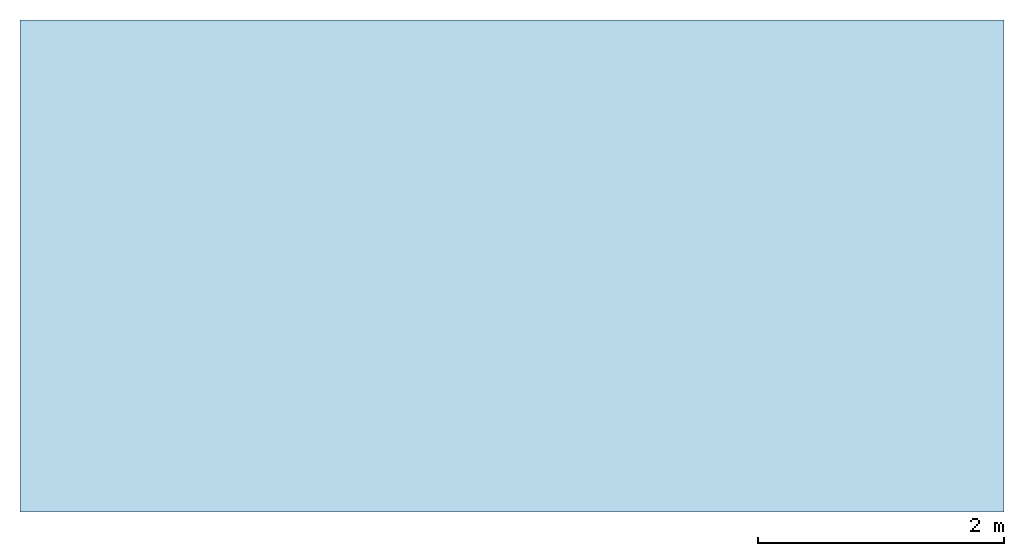
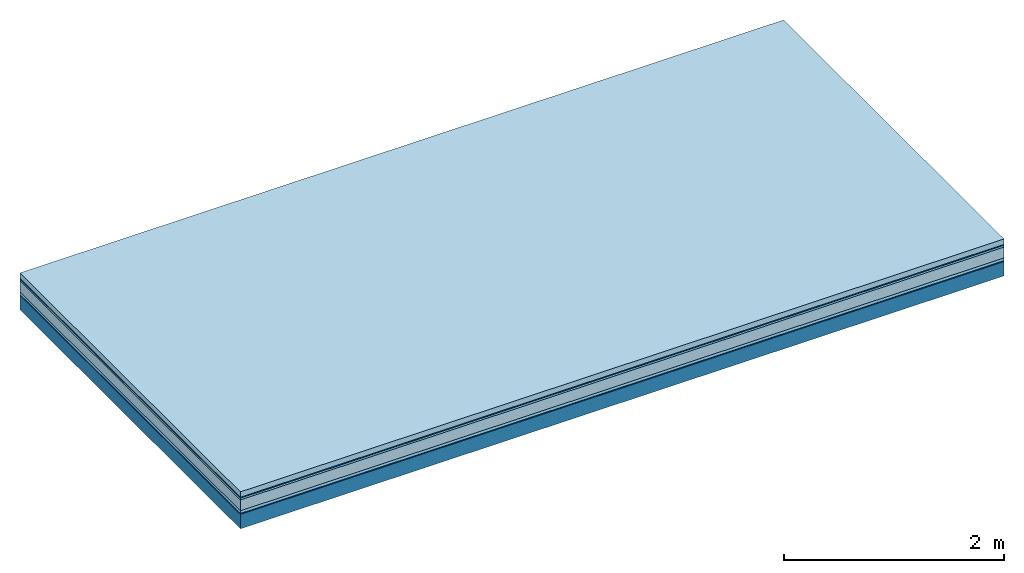
# One storey: 6 plates, 1 member, 1 element without a shape of its own.
"""IFC4 building model written with IfcOpenShell, lengths in metres."""

from ifc_helpers import new_model, si_unit, derived_unit, direction, frame, frame_2d, origin, origin_with_axes, place, context, project, spatial, rectangle, extrude, material, layer, layer_set, type_object, element, aggregate, save


model = new_model("IFC4")

# Units and contexts
plan_context = context("Plan", 3, precision=1e-05, world=origin(), true_north=direction((0.0, 1.0)))
model_context = context("Model", 3, precision=1e-05, world=origin(), true_north=direction((0.0, 1.0)))
ifc_project = project(units=[si_unit("LENGTHUNIT", "METRE"), derived_unit("SOUNDPRESSUREUNIT", [(si_unit("PRESSUREUNIT", "PASCAL", prefix="MICRO"), 0)]), si_unit("ENERGYUNIT", "JOULE", prefix="MEGA"), si_unit("MASSUNIT", "GRAM", prefix="KILO"), derived_unit("THERMALTRANSMITTANCEUNIT", [(si_unit("POWERUNIT", "WATT"), 1), (si_unit("AREAUNIT", "SQUARE_METRE"), -1), (si_unit("THERMODYNAMICTEMPERATUREUNIT", "KELVIN"), -1)]), derived_unit("AREADENSITYUNIT", [(si_unit("MASSUNIT", "GRAM", prefix="KILO"), 1), (si_unit("AREAUNIT", "SQUARE_METRE"), -1)]), derived_unit("USERDEFINED", [(si_unit("ENERGYUNIT", "JOULE", prefix="MEGA"), 1), (si_unit("AREAUNIT", "SQUARE_METRE"), -1)])], contexts=[plan_context, model_context])

# Site, building, storey
site = spatial("IfcSite", under=ifc_project)
building_placement = place(None, origin())
building = spatial("IfcBuilding", under=site, at=building_placement)
storey_placement = place(building_placement, origin())
storey = spatial("IfcBuildingStorey", under=building, at=storey_placement)

# Slab, member, plates
ifc_material_1 = material(Name="clay", Category="02.004")
ifc_layer_1 = layer(ifc_material_1, 0.06, Name="Use and protection layer 2")
ifc_material_2 = material(Name="Protective layer", Category="09.007")
ifc_layer_2 = layer(ifc_material_2, 0.01, Name="Use and protection layer 1")
ifc_material_3 = material(Name="Bituminous", Category="09.003")
ifc_layer_3 = layer(ifc_material_3, 0.02, Name="Seal")
ifc_material_4 = material(Category="10.006")
ifc_layer_4 = layer(ifc_material_4, 0.12, Name="Exterior insulation layer 2")
ifc_material_5 = material(Name="(034) 25 boards", Category="10.004")
ifc_layer_5 = layer(ifc_material_5, 0.03, Name="Exterior insulation layer 1")
ifc_material_6 = material(Name="Vapor-permeable barrier", Category="09.006")
ifc_layer_6 = layer(ifc_material_6, 0.01, Name="layer / temporary roof")
ifc_material_7 = material(Name="no composite action")
ifc_layer_7 = layer(ifc_material_7, 0.0, Name="Bond")
ifc_layer_8 = layer(None, 0.16, Name="Support")
ifc_layer_set = layer_set([ifc_layer_1, ifc_layer_2, ifc_layer_3, ifc_layer_4, ifc_layer_5, ifc_layer_6, ifc_layer_7, ifc_layer_8])
slab_type = type_object("IfcSlabType", Name="F0065", PredefinedType="NOTDEFINED", material=ifc_layer_set)
slab_placement = place(None, frame((0.0, 0.0, 0.0), z_axis=(0.0, 0.0, -1.0), x_axis=(1.0, 0.0, 0.0)))
slab = element("IfcSlab", 1, at=slab_placement, inside=storey, type_object=slab_type, material=ifc_layer_set, Name="Slab #1")
ifc_material_8 = material(Name="Solid timber panel")
member_placement = place(slab_placement, origin())
member = element("IfcMember", 2, at=member_placement, material=ifc_material_8, Name="Support", context=plan_context, shape_type="SweptSolid", body=[
    extrude(rectangle(XDim=1.0, YDim=0.16, at=frame_2d((0.5, 0.08), x_axis=(1.0, 0.0))), frame((0.0, 4.0, 0.25), z_axis=(0.0, -1.0, 0.0), x_axis=(1.0, 0.0, 0.0)), (0.0, 0.0, 1.0), 4.0),
    extrude(rectangle(XDim=1.0, YDim=0.16, at=frame_2d((0.5, 0.08), x_axis=(1.0, 0.0))), frame((1.0, 4.0, 0.25), z_axis=(0.0, -1.0, 0.0), x_axis=(1.0, 0.0, 0.0)), (0.0, 0.0, 1.0), 4.0),
    extrude(rectangle(XDim=1.0, YDim=0.16, at=frame_2d((0.5, 0.08), x_axis=(1.0, 0.0))), frame((2.0, 4.0, 0.25), z_axis=(0.0, -1.0, 0.0), x_axis=(1.0, 0.0, 0.0)), (0.0, 0.0, 1.0), 4.0),
    extrude(rectangle(XDim=1.0, YDim=0.16, at=frame_2d((0.5, 0.08), x_axis=(1.0, 0.0))), frame((3.0, 4.0, 0.25), z_axis=(0.0, -1.0, 0.0), x_axis=(1.0, 0.0, 0.0)), (0.0, 0.0, 1.0), 4.0),
    extrude(rectangle(XDim=1.0, YDim=0.16, at=frame_2d((0.5, 0.08), x_axis=(1.0, 0.0))), frame((4.0, 4.0, 0.25), z_axis=(0.0, -1.0, 0.0), x_axis=(1.0, 0.0, 0.0)), (0.0, 0.0, 1.0), 4.0),
    extrude(rectangle(XDim=1.0, YDim=0.16, at=frame_2d((0.5, 0.08), x_axis=(1.0, 0.0))), frame((5.0, 4.0, 0.25), z_axis=(0.0, -1.0, 0.0), x_axis=(1.0, 0.0, 0.0)), (0.0, 0.0, 1.0), 4.0),
    extrude(rectangle(XDim=1.0, YDim=0.16, at=frame_2d((0.5, 0.08), x_axis=(1.0, 0.0))), frame((6.0, 4.0, 0.25), z_axis=(0.0, -1.0, 0.0), x_axis=(1.0, 0.0, 0.0)), (0.0, 0.0, 1.0), 4.0),
    extrude(rectangle(XDim=1.0, YDim=0.16, at=frame_2d((0.5, 0.08), x_axis=(1.0, 0.0))), frame((7.0, 4.0, 0.25), z_axis=(0.0, -1.0, 0.0), x_axis=(1.0, 0.0, 0.0)), (0.0, 0.0, 1.0), 4.0),
])
plate_1_placement = place(slab_placement, origin())
plate_1 = element("IfcPlate", 3, at=plate_1_placement, material=ifc_material_1, Name="Use and protection layer 2", context=plan_context, shape_type="SweptSolid", body=[
    extrude(rectangle(XDim=8.0, YDim=4.0, at=frame_2d((4.0, 2.0), x_axis=(1.0, 0.0))), origin_with_axes(), (0.0, 0.0, 1.0), 0.06),
])
plate_2_placement = place(slab_placement, origin())
plate_2 = element("IfcPlate", 4, at=plate_2_placement, material=ifc_material_2, Name="Use and protection layer 1", context=plan_context, shape_type="SweptSolid", body=[
    extrude(rectangle(XDim=8.0, YDim=4.0, at=frame_2d((4.0, 2.0), x_axis=(1.0, 0.0))), frame((0.0, 0.0, 0.06), z_axis=(0.0, 0.0, 1.0), x_axis=(1.0, 0.0, 0.0)), (0.0, 0.0, 1.0), 0.01),
])
plate_3_placement = place(slab_placement, origin())
plate_3 = element("IfcPlate", 5, at=plate_3_placement, material=ifc_material_3, Name="Seal", context=plan_context, shape_type="SweptSolid", body=[
    extrude(rectangle(XDim=8.0, YDim=4.0, at=frame_2d((4.0, 2.0), x_axis=(1.0, 0.0))), frame((0.0, 0.0, 0.07), z_axis=(0.0, 0.0, 1.0), x_axis=(1.0, 0.0, 0.0)), (0.0, 0.0, 1.0), 0.02),
])
plate_4_placement = place(slab_placement, origin())
plate_4 = element("IfcPlate", 6, at=plate_4_placement, material=ifc_material_4, Name="Exterior insulation layer 2", context=plan_context, shape_type="SweptSolid", body=[
    extrude(rectangle(XDim=8.0, YDim=4.0, at=frame_2d((4.0, 2.0), x_axis=(1.0, 0.0))), frame((0.0, 0.0, 0.09), z_axis=(0.0, 0.0, 1.0), x_axis=(1.0, 0.0, 0.0)), (0.0, 0.0, 1.0), 0.12),
])
plate_5_placement = place(slab_placement, origin())
plate_5 = element("IfcPlate", 7, at=plate_5_placement, material=ifc_material_5, Name="Exterior insulation layer 1", context=plan_context, shape_type="SweptSolid", body=[
    extrude(rectangle(XDim=8.0, YDim=4.0, at=frame_2d((4.0, 2.0), x_axis=(1.0, 0.0))), frame((0.0, 0.0, 0.21), z_axis=(0.0, 0.0, 1.0), x_axis=(1.0, 0.0, 0.0)), (0.0, 0.0, 1.0), 0.03),
])
plate_6_placement = place(slab_placement, origin())
plate_6 = element("IfcPlate", 8, at=plate_6_placement, material=ifc_material_6, Name="layer / temporary roof", context=plan_context, shape_type="SweptSolid", body=[
    extrude(rectangle(XDim=8.0, YDim=4.0, at=frame_2d((4.0, 2.0), x_axis=(1.0, 0.0))), frame((0.0, 0.0, 0.24), z_axis=(0.0, 0.0, 1.0), x_axis=(1.0, 0.0, 0.0)), (0.0, 0.0, 1.0), 0.01),
])
aggregate(slab, [plate_1, plate_2, plate_3, plate_4, plate_5, plate_6, member])

save(model, "model.ifc")
